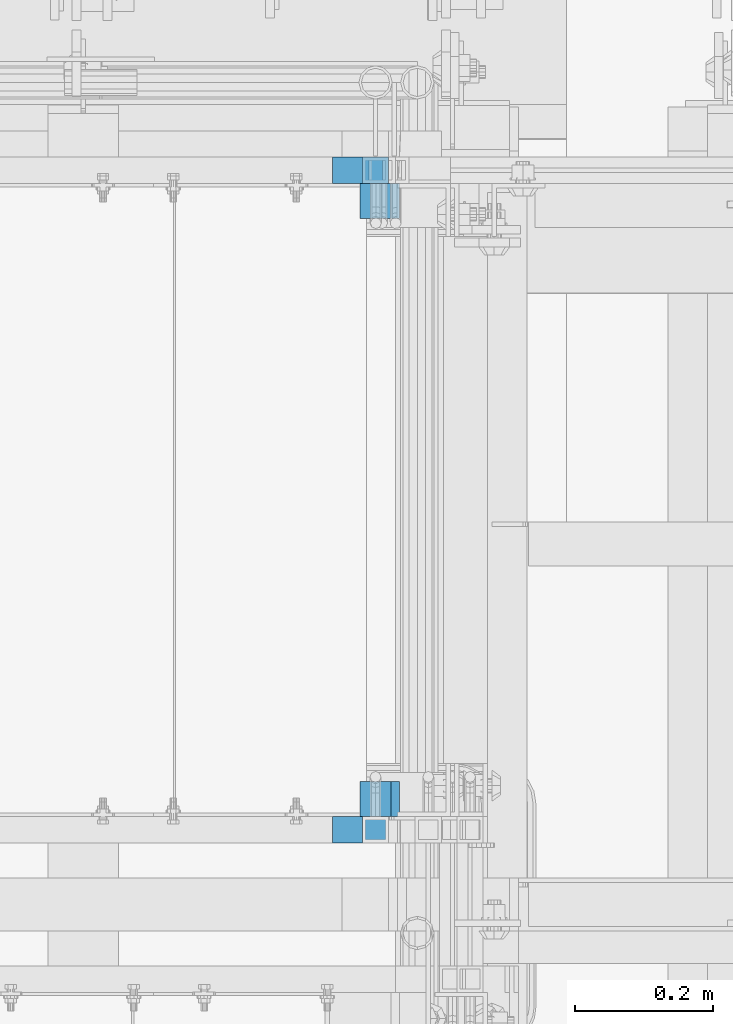
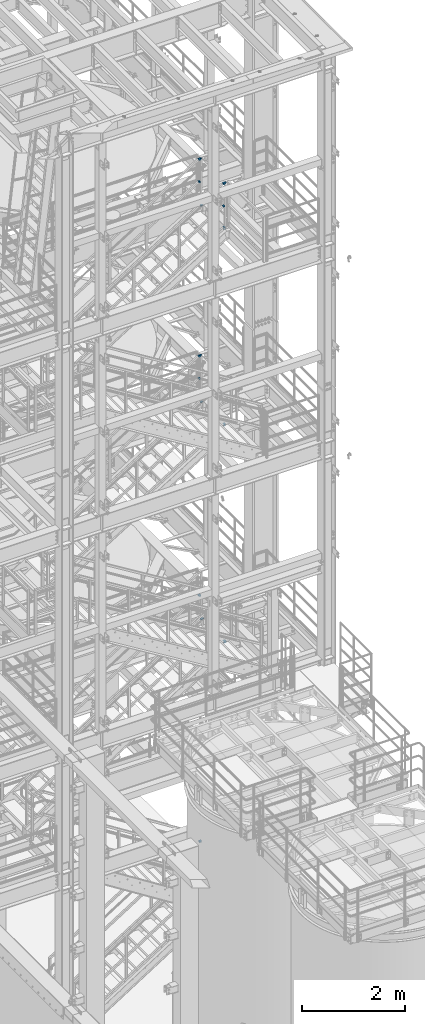
# One storey, part 1391 of 1876: 14 beams, 8 elements without a shape of their own.
"""IFC2X3 building model written with IfcOpenShell, lengths in millimetres."""

from ifc_helpers import new_model, si_unit, frame, origin_with_axes, place, context, subcontext, project, spatial, faceted_brep, material, type_object, element, aggregate, save


model = new_model("IFC2X3")

# Units and contexts
model_context = context("Model", 3, precision=1e-05, world=origin_with_axes())
body_context = subcontext(model_context, "Body", "Model", "MODEL_VIEW")
ifc_project = project(units=[si_unit("LENGTHUNIT", "METRE", prefix="MILLI"), si_unit("AREAUNIT", "SQUARE_METRE"), si_unit("VOLUMEUNIT", "CUBIC_METRE"), si_unit("MASSUNIT", "GRAM", prefix="KILO"), si_unit("TIMEUNIT", "SECOND"), si_unit("PLANEANGLEUNIT", "RADIAN"), si_unit("SOLIDANGLEUNIT", "STERADIAN"), si_unit("THERMODYNAMICTEMPERATUREUNIT", "DEGREE_CELSIUS"), si_unit("LUMINOUSINTENSITYUNIT", "LUMEN")], contexts=[model_context])

# Site, building, storey
site_placement = place(None, origin_with_axes())
site = spatial("IfcSite", under=ifc_project, at=site_placement, CompositionType="ELEMENT")
building_placement = place(site_placement, origin_with_axes())
building = spatial("IfcBuilding", under=site, at=building_placement, Name="Undefined", CompositionType="ELEMENT")
storey_placement = place(building_placement, origin_with_axes())
storey = spatial("IfcBuildingStorey", under=building, at=storey_placement, Name="Undefined", CompositionType="ELEMENT", Elevation=0.0)

# Assembly, beam
assembly_1_placement = place(storey_placement, origin_with_axes())
assembly_1 = element("IfcElementAssembly", 1, at=assembly_1_placement, inside=storey, Name="RAIL", AssemblyPlace="NOTDEFINED", PredefinedType="RIGID_FRAME")
ifc_material_1 = material()
beam_type_1 = type_object("IfcBeamType", Name="HSS1-1/2X1-1/2X1/8", PredefinedType="NOTDEFINED")
beam_1_placement = place(assembly_1_placement, frame((6080.61607488407, -4781.55000191054, 19049.9950194572), z_axis=(0.0, 0.0, -1.0), x_axis=(1.0, 0.0, 0.0)))
beam_1 = element("IfcBeam", 2, at=beam_1_placement, type_object=beam_type_1, material=ifc_material_1, Name="RAIL", ObjectType="HSS1-1/2X1-1/2X1/8", context=body_context, shape_type="Brep", body=[
    faceted_brep([(-4.50933858131521, 15.8749992829999, -15.8749992830017), (-4.50933858131521, -15.8749992829999, -15.8749992830017), (72.528955442076, -15.8749992829999, -15.8749992830017), (72.528955442076, 15.8749992829999, -15.8749992830017), (4.52825540216872, -15.8749992829999, 15.8749992830017), (40.7790810727693, -15.8749992829999, 15.8749992830017), (4.52825540216872, 15.8749992829999, 15.8749992830017), (40.7790810727693, 15.8749992829999, 15.8749992830017), (-5.41309800681847, 19.0499992349996, -19.0499992350015), (5.4320148276729, 19.0499992349996, 19.0499992350015), (37.604093540439, 19.0499992349996, 19.0499992350015), (75.7039429744073, 19.0499992349996, -19.0499992350015), (5.4320148276729, -19.0499992349996, 19.0499992350015), (37.604093540439, -19.0499992349996, 19.0499992350015), (-5.41309800681847, -19.0499992349996, -19.0499992350015), (75.7039429744073, -19.0499992349996, -19.0499992350015)], [[[0, 1, 2, 3]], [[1, 4, 5, 2]], [[4, 6, 7, 5]], [[6, 0, 3, 7]], [[8, 9, 10, 11]], [[9, 12, 13, 10]], [[12, 14, 15, 13]], [[14, 8, 11, 15]], [[13, 15, 11, 10], [5, 7, 3, 2]], [[14, 12, 9, 8], [6, 4, 1, 0]]]),
])

# Assembly, beams
assembly_2_placement = place(storey_placement, origin_with_axes())
assembly_2 = element("IfcElementAssembly", 3, at=assembly_2_placement, inside=storey, Name="RAIL", AssemblyPlace="NOTDEFINED", PredefinedType="RIGID_FRAME")
beam_2_placement = place(assembly_2_placement, frame((6080.51600985087, -4781.55000191054, 14376.3999999999), z_axis=(0.0, 0.0, -1.0), x_axis=(1.0, 0.0, 0.0)))
beam_2 = element("IfcBeam", 4, at=beam_2_placement, type_object=beam_type_1, material=ifc_material_1, Name="RAIL", ObjectType="HSS1-1/2X1-1/2X1/8", context=body_context, shape_type="Brep", body=[
    faceted_brep([(-4.49184492785935, 15.8749992829999, -15.8749992829999), (-4.49184492785935, -15.8749992829999, -15.8749992829999), (72.6339894773, -15.8749992829999, -15.8749992829999), (72.6339894773, 15.8749992829999, -15.8749992829999), (4.49184492431232, -15.8749992829999, 15.8749992829999), (40.883992123634, -15.8749992829999, 15.8749992829999), (4.49184492431232, 15.8749992829999, 15.8749992829999), (40.883992123634, 15.8749992829999, 15.8749992829999), (-5.39021394007068, 19.0499992349996, -19.0499992349996), (5.39021393652274, 19.0499992349996, 19.0499992349996), (37.7089922928681, 19.0499992349996, 19.0499992349996), (75.808989308066, 19.0499992349996, -19.0499992349996), (5.39021393652274, -19.0499992349996, 19.0499992349996), (37.7089922928681, -19.0499992349996, 19.0499992349996), (-5.39021394007068, -19.0499992349996, -19.0499992349996), (75.808989308066, -19.0499992349996, -19.0499992349996)], [[[0, 1, 2, 3]], [[1, 4, 5, 2]], [[4, 6, 7, 5]], [[6, 0, 3, 7]], [[8, 9, 10, 11]], [[9, 12, 13, 10]], [[12, 14, 15, 13]], [[14, 8, 11, 15]], [[13, 15, 11, 10], [5, 7, 3, 2]], [[14, 12, 9, 8], [6, 4, 1, 0]]]),
])
beam_3_placement = place(assembly_2_placement, frame((6080.51600984769, -4781.55000114554, 13843.0000000052), z_axis=(0.0, 0.0, 1.0), x_axis=(1.0, 0.0, 0.0)))
beam_3 = element("IfcBeam", 5, at=beam_3_placement, type_object=beam_type_1, material=ifc_material_1, Name="RAIL", ObjectType="HSS1-1/2X1-1/2X1/8", context=body_context, shape_type="Brep", body=[
    faceted_brep([(4.49184492398945, 15.8749992829999, -15.8749992829999), (4.49184492398945, -15.8749992829999, -15.8749992829999), (37.7089908702219, -15.8749992829999, -15.8749992829999), (37.7089908702219, 15.8749992829999, -15.8749992829999), (-4.49184492818313, -15.8749992829999, 15.8749992829999), (37.7089908702219, -15.8749992829999, 15.8749992829999), (-4.49184492818313, 15.8749992829999, 15.8749992829999), (37.7089908702219, 15.8749992829999, 15.8749992829999), (5.39021393619987, 19.0499992349996, -19.0499992349996), (-5.39021394039355, 19.0499992349996, 19.0499992349996), (37.7089922928681, 19.0499992349996, 19.0499992349996), (37.7089908702219, 19.0499992349996, -19.0499992349996), (-5.39021394039355, -19.0499992349996, 19.0499992349996), (37.7089922928681, -19.0499992349996, 19.0499992349996), (5.39021393619987, -19.0499992349996, -19.0499992349996), (37.7089908702219, -19.0499992349996, -19.0499992349996)], [[[0, 1, 2, 3]], [[1, 4, 5, 2]], [[4, 6, 7, 5]], [[6, 0, 3, 7]], [[8, 9, 10, 11]], [[9, 12, 13, 10]], [[12, 14, 15, 13]], [[14, 8, 11, 15]], [[13, 15, 11, 10], [5, 7, 3, 2]], [[14, 12, 9, 8], [6, 4, 1, 0]]]),
])
aggregate(assembly_2, [beam_2, beam_3])

# Assembly, beam
assembly_3_placement = place(storey_placement, origin_with_axes())
assembly_3 = element("IfcElementAssembly", 6, at=assembly_3_placement, inside=storey, Name="RAIL", AssemblyPlace="NOTDEFINED", PredefinedType="RIGID_FRAME")
beam_4_placement = place(assembly_3_placement, frame((6081.03214428076, -4781.55000114554, 8686.79999873524), z_axis=(0.0, 0.0, 1.0), x_axis=(1.0, 0.0, 0.0)))
beam_4 = element("IfcBeam", 7, at=beam_4_placement, type_object=beam_type_1, material=ifc_material_1, Name="RAIL", ObjectType="HSS1-1/2X1-1/2X1/8", context=body_context, shape_type="Brep", body=[
    faceted_brep([(4.62281070603149, 15.8749992829999, -15.8749992829999), (4.62281070603149, -15.8749992829999, -15.8749992829999), (46.7178505228021, -15.8749992829999, -15.8749992829999), (46.7178505228021, 15.8749992829999, -15.8749992829999), (-4.62281069892288, -15.8749992829999, 15.8749992829999), (46.7178505228021, -15.8749992829999, 15.8749992829999), (-4.62281069892288, 15.8749992829999, 15.8749992829999), (46.7178505228021, 15.8749992829999, 15.8749992829999), (5.54737287430726, 19.0499992349996, -19.0499992349996), (-5.54737286719865, 19.0499992349996, 19.0499992349996), (46.7178505314432, 19.0499992349996, 19.0499992349996), (46.7178505228021, 19.0499992349996, -19.0499992349996), (-5.54737286719865, -19.0499992349996, 19.0499992349996), (46.7178505314432, -19.0499992349996, 19.0499992349996), (5.54737287430726, -19.0499992349996, -19.0499992349996), (46.7178505228021, -19.0499992349996, -19.0499992349996)], [[[0, 1, 2, 3]], [[1, 4, 5, 2]], [[4, 6, 7, 5]], [[6, 0, 3, 7]], [[8, 9, 10, 11]], [[9, 12, 13, 10]], [[12, 14, 15, 13]], [[14, 8, 11, 15]], [[13, 15, 11, 10], [5, 7, 3, 2]], [[14, 12, 9, 8], [6, 4, 1, 0]]]),
])
aggregate(assembly_3, [beam_4])

assembly_4_placement = place(storey_placement, origin_with_axes())
assembly_4 = element("IfcElementAssembly", 8, at=assembly_4_placement, inside=storey, Name="RAIL", AssemblyPlace="NOTDEFINED", PredefinedType="RIGID_FRAME")
beam_5_placement = place(assembly_4_placement, frame((6096.00000038111, -4781.55000114554, 2837.68362061127), z_axis=(0.0, 0.0, 1.0), x_axis=(1.0, 0.0, 0.0)))
beam_5 = element("IfcBeam", 9, at=beam_5_placement, type_object=beam_type_1, material=ifc_material_1, Name="RAIL", ObjectType="HSS1-1/2X1-1/2X1/8", context=body_context, shape_type="Brep", body=[
    faceted_brep([(4.61079483309095, 15.8749992829999, -15.8749992829999), (4.61079483309095, -15.8749992829999, -15.8749992829999), (51.1968753963729, -15.8749992829999, -15.8749992829999), (51.1968753963729, 15.8749992829999, -15.8749992829999), (-4.61079482670993, -15.8749992829999, 15.8749992829999), (51.1968753963729, -15.8749992829999, 15.8749992829999), (-4.61079482670993, 15.8749992829999, 15.8749992829999), (51.1968753963729, 15.8749992829999, 15.8749992829999), (5.5329538267797, 19.0499992349996, -19.0499992350001), (-5.53295382039778, 19.0499992349996, 19.0499992350001), (51.1968753963729, 19.0499992349996, 19.0499992350001), (51.1968753963729, 19.0499992349996, -19.0499992350001), (-5.53295382039778, -19.0499992349996, 19.0499992350001), (51.1968753963729, -19.0499992349996, 19.0499992350001), (5.5329538267797, -19.0499992349996, -19.0499992350001), (51.1968753963729, -19.0499992349996, -19.0499992350001)], [[[0, 1, 2, 3]], [[1, 4, 5, 2]], [[4, 6, 7, 5]], [[6, 0, 3, 7]], [[8, 9, 10, 11]], [[9, 12, 13, 10]], [[12, 14, 15, 13]], [[14, 8, 11, 15]], [[13, 15, 11, 10], [5, 7, 3, 2]], [[14, 12, 9, 8], [6, 4, 1, 0]]]),
])
aggregate(assembly_4, [beam_5])

# Beam
beam_6_placement = place(assembly_1_placement, frame((6080.62411545839, -4781.55000114554, 18516.6000004146), z_axis=(0.000132472000011148, 0.0, 0.999999991225585), x_axis=(0.999999991225585, 0.0, -0.000132472000011518)))
beam_6 = element("IfcBeam", 10, at=beam_6_placement, type_object=beam_type_1, material=ifc_material_1, Name="RAIL", ObjectType="HSS1-1/2X1-1/2X1/8", context=body_context, shape_type="Brep", body=[
    faceted_brep([(4.52107047996014, 15.8749992829999, -15.8749992829944), (4.52107047996014, -15.8749992829999, -15.8749992829944), (37.6008852440546, -15.8749992829999, -15.8749992829798), (37.6008852440546, 15.8749992829999, -15.8749992829798), (-4.52107045019329, -15.8749992829999, 15.874999282998), (37.6008852440445, -15.8749992829999, 15.8749992830053), (-4.52107045019329, 15.8749992829999, 15.874999282998), (37.6008852440445, 15.8749992829999, 15.8749992830053), (5.42528460014546, 19.0499992349996, -19.0499992349905), (-5.42528457037679, 19.0499992349996, 19.0499992349905), (37.6008852440445, 19.0499992349996, 19.0499992350087), (37.6008852440573, 19.0499992349996, -19.0499992349796), (-5.42528457037679, -19.0499992349996, 19.0499992349905), (37.6008852440445, -19.0499992349996, 19.0499992350087), (5.42528460014546, -19.0499992349996, -19.0499992349905), (37.6008852440573, -19.0499992349996, -19.0499992349796)], [[[0, 1, 2, 3]], [[1, 4, 5, 2]], [[4, 6, 7, 5]], [[6, 0, 3, 7]], [[8, 9, 10, 11]], [[9, 12, 13, 10]], [[12, 14, 15, 13]], [[14, 8, 11, 15]], [[13, 15, 11, 10], [5, 7, 3, 2]], [[14, 12, 9, 8], [6, 4, 1, 0]]]),
])

aggregate(assembly_1, [beam_1, beam_6])

# Assembly, beams
assembly_5_placement = place(storey_placement, origin_with_axes())
assembly_5 = element("IfcElementAssembly", 11, at=assembly_5_placement, inside=storey, Name="RAIL", AssemblyPlace="NOTDEFINED", PredefinedType="RIGID_FRAME")
beam_7_placement = place(assembly_5_placement, frame((6080.62411545953, -5734.05000114554, 18516.6000004146), z_axis=(0.0, 0.0, 1.0), x_axis=(1.0, 0.0, 0.0)))
beam_7 = element("IfcBeam", 12, at=beam_7_placement, type_object=beam_type_1, material=ifc_material_1, Name="RAIL", ObjectType="HSS1-1/2X1-1/2X1/8", context=body_context, shape_type="Brep", body=[
    faceted_brep([(4.51879699173378, 15.8749992829999, -15.8749992830017), (4.51879699173378, -15.8749992829999, -15.8749992830017), (37.6008852440546, -15.8749992829999, -15.8749992829798), (37.6008852440546, 15.8749992829999, -15.8749992829798), (-4.51879699175015, -15.8749992829999, 15.8749992830017), (37.6008852440445, -15.8749992829999, 15.8749992830053), (-4.51879699175015, 15.8749992829999, 15.8749992830017), (37.6008852440445, 15.8749992829999, 15.8749992830053), (5.4225564172375, 19.0499992349996, -19.0499992350015), (-5.42255641725387, 19.0499992349996, 19.0499992350015), (37.6008852440445, 19.0499992349996, 19.0499992350087), (37.6008852440573, 19.0499992349996, -19.0499992349796), (-5.42255641725387, -19.0499992349996, 19.0499992350015), (37.6008852440445, -19.0499992349996, 19.0499992350087), (5.4225564172375, -19.0499992349996, -19.0499992350015), (37.6008852440573, -19.0499992349996, -19.0499992349796)], [[[0, 1, 2, 3]], [[1, 4, 5, 2]], [[4, 6, 7, 5]], [[6, 0, 3, 7]], [[8, 9, 10, 11]], [[9, 12, 13, 10]], [[12, 14, 15, 13]], [[14, 8, 11, 15]], [[13, 15, 11, 10], [5, 7, 3, 2]], [[14, 12, 9, 8], [6, 4, 1, 0]]]),
])
beam_8_placement = place(assembly_5_placement, frame((6137.27499723592, -5734.05000114554, 19050.0000003796), z_axis=(0.0, 0.0, -1.0), x_axis=(-1.0, 0.0, 0.0)))
beam_8 = element("IfcBeam", 13, at=beam_8_placement, type_object=beam_type_1, material=ifc_material_1, Name="RAIL", ObjectType="HSS1-1/2X1-1/2X1/8", context=body_context, shape_type="Brep", body=[
    faceted_brep([(-15.875, 15.8749981318675, -15.875), (-15.875, -15.8750000000011, -15.875), (61.1696787857327, -15.8749992829999, -15.8749992830271), (61.1696787857327, 15.8749992829999, -15.8749992830271), (15.875, -15.8750000000011, 15.875), (52.1320847679253, -15.8749992829999, 15.8749992829762), (15.875, 15.8749981318675, 15.875), (52.1320847679253, 15.8749992829999, 15.8749992829762), (-19.049999234363, 19.0499992349996, -19.0499992350001), (19.0500000000002, 19.0499992349996, 19.0499992350001), (51.2283253389896, 19.0499992349996, 19.049999234976), (62.0734382146693, 19.0499992349996, -19.0499992350306), (19.0500000000002, -19.0499992349996, 19.0499992350001), (51.2283253389896, -19.0499992349996, 19.049999234976), (-19.049999234363, -19.0499992349996, -19.0499992350001), (62.0734382146693, -19.0499992349996, -19.0499992350306)], [[[0, 1, 2, 3]], [[1, 4, 5, 2]], [[4, 6, 7, 5]], [[6, 0, 3, 7]], [[8, 9, 10, 11]], [[9, 12, 13, 10]], [[12, 14, 15, 13]], [[14, 8, 11, 15]], [[13, 15, 11, 10], [5, 7, 3, 2]], [[14, 12, 9, 8], [6, 4, 1, 0]]]),
])
aggregate(assembly_5, [beam_7, beam_8])

assembly_6_placement = place(storey_placement, origin_with_axes())
assembly_6 = element("IfcElementAssembly", 14, at=assembly_6_placement, inside=storey, Name="STRINGER", AssemblyPlace="NOTDEFINED", PredefinedType="RIGID_FRAME")
ifc_material_2 = material(Name="STEEL/A36")
beam_type_2 = type_object("IfcBeamType", Name="L2X2X1/4", PredefinedType="NOTDEFINED")
beam_9_placement = place(assembly_6_placement, frame((6159.49999963979, -5689.59999886891, 17957.8000005856), z_axis=(0.0, 1.0, 0.0), x_axis=(-1.0, 0.0, 0.0)))
beam_9 = element("IfcBeam", 15, at=beam_9_placement, type_object=beam_type_2, material=ifc_material_2, Name="ANGLE", ObjectType="L2X2X1/4", context=body_context, shape_type="Brep", body=[
    faceted_brep([(0.0, 25.3999999999996, -25.3999999999996), (0.0, 25.3999999999996, 25.3999999999996), (44.449999999998, 25.4000000000015, 25.3999999999996), (44.449999999998, 25.4000000000015, -25.3999999999996), (0.0, 19.0500000000002, 25.3999999999996), (44.449999999998, 19.0499999999993, 25.3999999999996), (0.0, 19.0499992349996, -19.0499992350001), (44.449999999998, 19.0499999999993, -19.0500000000002), (0.0, -25.3999999999996, -19.0500000000002), (44.449999999998, -25.4000000000015, -19.0500000000002), (0.0, -25.3999999999996, -25.3999999999996), (44.449999999998, -25.4000000000015, -25.3999999999996)], [[[0, 1, 2, 3]], [[1, 4, 5, 2]], [[4, 6, 7, 5]], [[6, 8, 9, 7]], [[8, 10, 11, 9]], [[10, 0, 3, 11]], [[5, 7, 9, 11, 3, 2]], [[10, 8, 6, 4, 1, 0]]]),
])
beam_10_placement = place(assembly_6_placement, frame((6115.04999963979, -4826.00000113109, 17957.8000005856), z_axis=(0.0, -1.0, 0.0), x_axis=(1.0, 0.0, 0.0)))
beam_10 = element("IfcBeam", 16, at=beam_10_placement, type_object=beam_type_2, material=ifc_material_2, Name="ANGLE", ObjectType="L2X2X1/4", context=body_context, shape_type="Brep", body=[
    faceted_brep([(0.0, 25.3999999999996, -25.3999999999996), (0.0, 25.3999999999996, 25.3999999999996), (44.449999999998, 25.4000000000015, 25.3999999999996), (44.449999999998, 25.4000000000015, -25.3999999999996), (0.0, 19.0500000000002, 25.3999999999996), (44.449999999998, 19.0499999999993, 25.3999999999996), (0.0, 19.0499992349996, -19.0499992350001), (44.449999999998, 19.0499999999993, -19.0500000000002), (0.0, -25.3999999999996, -19.0500000000002), (44.449999999998, -25.4000000000015, -19.0500000000002), (0.0, -25.3999999999996, -25.3999999999996), (44.449999999998, -25.4000000000015, -25.3999999999996)], [[[0, 1, 2, 3]], [[1, 4, 5, 2]], [[4, 6, 7, 5]], [[6, 8, 9, 7]], [[8, 10, 11, 9]], [[10, 0, 3, 11]], [[5, 7, 9, 11, 3, 2]], [[10, 8, 6, 4, 1, 0]]]),
])
aggregate(assembly_6, [beam_9, beam_10])

assembly_7_placement = place(storey_placement, origin_with_axes())
assembly_7 = element("IfcElementAssembly", 17, at=assembly_7_placement, inside=storey, Name="STRINGER", AssemblyPlace="NOTDEFINED", PredefinedType="RIGID_FRAME")
beam_11_placement = place(assembly_7_placement, frame((6159.50000002258, -5689.59999888316, 13287.3750005856), z_axis=(0.0, 1.0, 0.0), x_axis=(-1.0, 0.0, 0.0)))
beam_11 = element("IfcBeam", 18, at=beam_11_placement, type_object=beam_type_2, material=ifc_material_2, Name="ANGLE", ObjectType="L2X2X1/4", context=body_context, shape_type="Brep", body=[
    faceted_brep([(0.0, 25.3999999999996, -25.3999999999996), (0.0, 25.3999999999996, 25.3999999999996), (44.449999999998, 25.4000000000015, 25.3999999999996), (44.449999999998, 25.4000000000015, -25.3999999999996), (0.0, 19.0500000000002, 25.3999999999996), (44.449999999998, 19.0499999999993, 25.3999999999996), (0.0, 19.0499992349996, -19.0499992350001), (44.449999999998, 19.0499999999993, -19.0500000000002), (0.0, -25.3999999999996, -19.0500000000002), (44.449999999998, -25.4000000000015, -19.0500000000002), (0.0, -25.3999999999996, -25.3999999999996), (44.449999999998, -25.4000000000015, -25.3999999999996)], [[[0, 1, 2, 3]], [[1, 4, 5, 2]], [[4, 6, 7, 5]], [[6, 8, 9, 7]], [[8, 10, 11, 9]], [[10, 0, 3, 11]], [[5, 7, 9, 11, 3, 2]], [[10, 8, 6, 4, 1, 0]]]),
])
beam_12_placement = place(assembly_7_placement, frame((6115.05000002258, -4826.00000114534, 13287.3750005146), z_axis=(0.0, -1.0, 0.0), x_axis=(1.0, 0.0, 0.0)))
beam_12 = element("IfcBeam", 19, at=beam_12_placement, type_object=beam_type_2, material=ifc_material_2, Name="ANGLE", ObjectType="L2X2X1/4", context=body_context, shape_type="Brep", body=[
    faceted_brep([(0.0, 25.3999999999996, -25.3999999999996), (0.0, 25.3999999999996, 25.3999999999996), (44.449999999998, 25.4000000000015, 25.3999999999996), (44.449999999998, 25.4000000000015, -25.3999999999996), (0.0, 19.0500000000002, 25.3999999999996), (44.449999999998, 19.0499999999993, 25.3999999999996), (0.0, 19.0499992349996, -19.0499992350001), (44.449999999998, 19.0499999999993, -19.0500000000002), (0.0, -25.3999999999996, -19.0500000000002), (44.449999999998, -25.4000000000015, -19.0500000000002), (0.0, -25.3999999999996, -25.3999999999996), (44.449999999998, -25.4000000000015, -25.3999999999996)], [[[0, 1, 2, 3]], [[1, 4, 5, 2]], [[4, 6, 7, 5]], [[6, 8, 9, 7]], [[8, 10, 11, 9]], [[10, 0, 3, 11]], [[5, 7, 9, 11, 3, 2]], [[10, 8, 6, 4, 1, 0]]]),
])
aggregate(assembly_7, [beam_11, beam_12])

assembly_8_placement = place(storey_placement, origin_with_axes())
assembly_8 = element("IfcElementAssembly", 20, at=assembly_8_placement, inside=storey, Name="STRINGER", AssemblyPlace="NOTDEFINED", PredefinedType="RIGID_FRAME")
beam_13_placement = place(assembly_8_placement, frame((6172.19999407089, -5689.59999885719, 8131.17499862696), z_axis=(0.0, 1.0, 0.0), x_axis=(-1.0, 0.0, 0.0)))
beam_13 = element("IfcBeam", 21, at=beam_13_placement, type_object=beam_type_2, material=ifc_material_2, Name="ANGLE", ObjectType="L2X2X1/4", context=body_context, shape_type="Brep", body=[
    faceted_brep([(0.0, 25.3999999999996, -25.3999999999996), (0.0, 25.3999999999996, 25.3999999999996), (57.1500000000033, 25.3999999999996, 25.3999999999996), (57.1500000000033, 25.3999999999996, -25.3999999999996), (0.0, 19.0500000000002, 25.3999999999996), (57.1500000000033, 19.0500000000002, 25.3999999999996), (0.0, 19.0499992349996, -19.0499992350001), (57.1500000000033, 19.0500000000002, -19.0500000000002), (0.0, -25.3999999999996, -19.0500000000002), (57.1500000000033, -25.3999999999996, -19.0500000000002), (0.0, -25.3999999999996, -25.3999999999996), (57.1500000000033, -25.3999999999996, -25.3999999999996)], [[[0, 1, 2, 3]], [[1, 4, 5, 2]], [[4, 6, 7, 5]], [[6, 8, 9, 7]], [[8, 10, 11, 9]], [[10, 0, 3, 11]], [[5, 7, 9, 11, 3, 2]], [[10, 8, 6, 4, 1, 0]]]),
])
beam_14_placement = place(assembly_8_placement, frame((6115.04999407088, -4826.00000111937, 8131.17499862695), z_axis=(0.0, -1.0, 0.0), x_axis=(1.0, 0.0, 0.0)))
beam_14 = element("IfcBeam", 22, at=beam_14_placement, type_object=beam_type_2, material=ifc_material_2, Name="ANGLE", ObjectType="L2X2X1/4", context=body_context, shape_type="Brep", body=[
    faceted_brep([(0.0, 25.3999999999996, -25.3999999999996), (0.0, 25.3999999999996, 25.3999999999996), (57.1500000000033, 25.3999999999996, 25.3999999999996), (57.1500000000033, 25.3999999999996, -25.3999999999996), (0.0, 19.0500000000002, 25.3999999999996), (57.1500000000033, 19.0500000000002, 25.3999999999996), (0.0, 19.0499992349996, -19.0499992350001), (57.1500000000033, 19.0500000000002, -19.0500000000002), (0.0, -25.3999999999996, -19.0500000000002), (57.1500000000033, -25.3999999999996, -19.0500000000002), (0.0, -25.3999999999996, -25.3999999999996), (57.1500000000033, -25.3999999999996, -25.3999999999996)], [[[0, 1, 2, 3]], [[1, 4, 5, 2]], [[4, 6, 7, 5]], [[6, 8, 9, 7]], [[8, 10, 11, 9]], [[10, 0, 3, 11]], [[5, 7, 9, 11, 3, 2]], [[10, 8, 6, 4, 1, 0]]]),
])
aggregate(assembly_8, [beam_13, beam_14])

save(model, "model.ifc")
